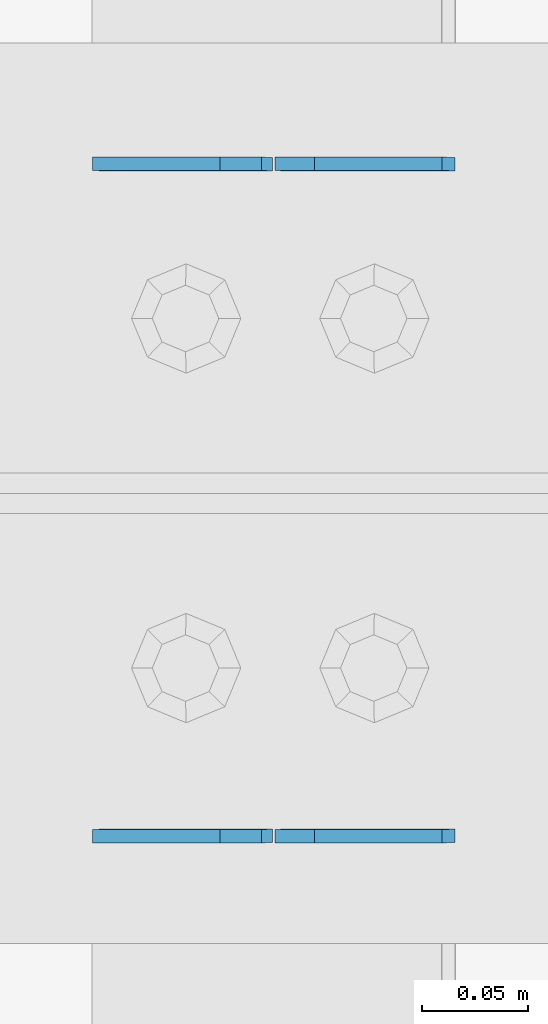
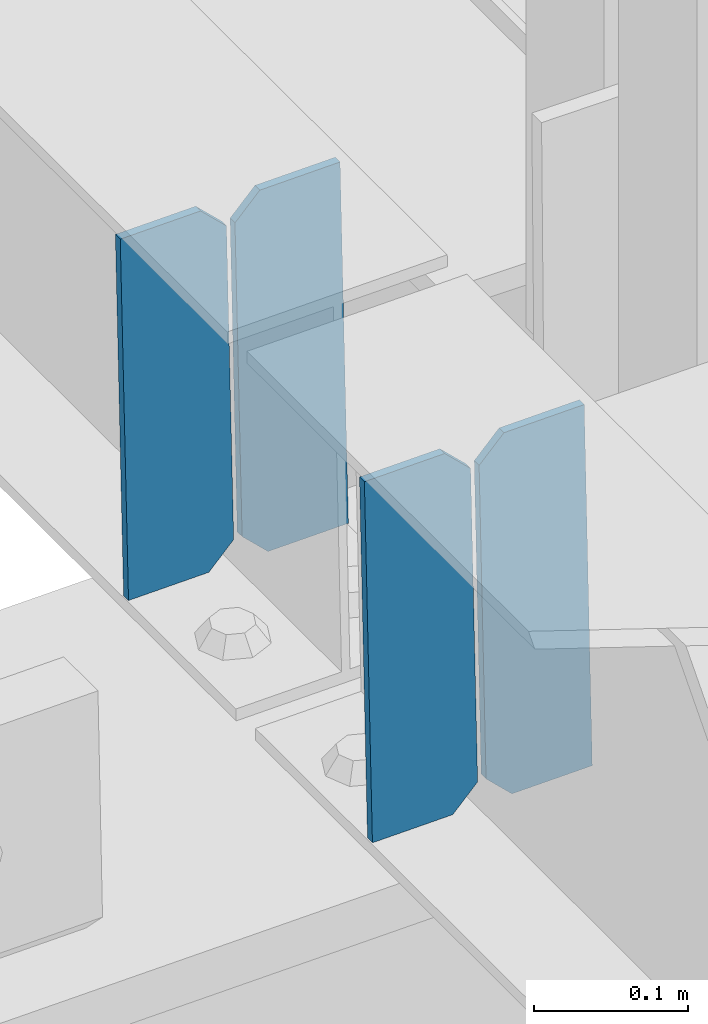
# One storey, part 3319 of 3843: 4 plates, 2 elements without a shape of their own.
"""IFC2X3 building model written with IfcOpenShell, lengths in millimetres."""

import ifcopenshell
import ifcopenshell.guid

model = None  # the IFC model being written
_history = None  # IfcOwnerHistory: only IFC2X3 demands one
_inside = {}  # id of a spatial element -> (the spatial element, [elements in it])
_under = {}  # id of a project, library or spatial element -> (it, [spatial elements below it])
_declared = {}  # id of a project -> (the project, [libraries it declares])
_typed = {}  # id of a type object -> (the type object, [elements of that type])
_made_of = {}  # id of a material, layer set ... -> (it, [elements and type objects made of it])


def new_model(schema):
    """Start an empty IFC model of exactly this schema.

    Asked for "IFC4X3", IfcOpenShell would pick the latest addendum, in which some entities
    have other attributes; the version numbers below select the first issue.
    IFC2X3 requires an IfcOwnerHistory on every rooted entity: one is made here for all.
    """
    global model, _history
    if schema == "IFC4X3":
        model = ifcopenshell.file(schema_version=(4, 3, 0, 0))
    else:
        model = ifcopenshell.file(schema=schema)
    _inside.clear()
    _under.clear()
    _declared.clear()
    _typed.clear()
    _made_of.clear()
    _history = None
    if model.schema == "IFC2X3":
        org = make("IfcOrganization", Name="unknown")
        user = make(
            "IfcPersonAndOrganization",
            ThePerson=make("IfcPerson", FamilyName="unknown"),
            TheOrganization=org,
        )
        app = make(
            "IfcApplication",
            ApplicationDeveloper=org,
            Version="unknown",
            ApplicationFullName="unknown",
            ApplicationIdentifier="unknown",
        )
        _history = make(
            "IfcOwnerHistory",
            OwningUser=user,
            OwningApplication=app,
            ChangeAction="ADDED",
            CreationDate=0,
        )
    return model


def make(cls, **values):
    """One entity of the class cls with the attributes given. An attribute that is None is left unset."""
    return model.create_entity(
        cls, **{name: value for name, value in values.items() if value is not None}
    )


def rooted(cls, **values):
    """An entity with a GlobalId (a new one), such as an element, a storey or a relation."""
    return make(cls, GlobalId=ifcopenshell.guid.new(), OwnerHistory=_history, **values)


def si_unit(unit_type, name, prefix=None):
    """IfcSIUnit, for example si_unit("LENGTHUNIT", "METRE", prefix="MILLI")."""
    return make("IfcSIUnit", UnitType=unit_type, Prefix=prefix, Name=name)


def assignment(units):
    """IfcUnitAssignment: the units of a project."""
    return None if units is None else make("IfcUnitAssignment", Units=units)


def point(xyz):
    """IfcCartesianPoint."""
    return None if xyz is None else make("IfcCartesianPoint", Coordinates=xyz)


def direction(xyz):
    """IfcDirection."""
    return None if xyz is None else make("IfcDirection", DirectionRatios=xyz)


def frame(location, z_axis=None, x_axis=None):
    """IfcAxis2Placement3D, a coordinate frame: its origin and axes. An axis left out is left unset."""
    return make(
        "IfcAxis2Placement3D",
        Location=point(location),
        Axis=direction(z_axis),
        RefDirection=direction(x_axis),
    )


def origin_with_axes():
    """The frame at (0, 0, 0) with the z axis (0, 0, 1) and the x axis (1, 0, 0) written out."""
    return frame((0.0, 0.0, 0.0), z_axis=(0.0, 0.0, 1.0), x_axis=(1.0, 0.0, 0.0))


def place(relative_to, where):
    """IfcLocalPlacement: puts the frame where relative to a parent placement (None: the world)."""
    return make(
        "IfcLocalPlacement", PlacementRelTo=relative_to, RelativePlacement=where
    )


def context(
    kind, dimensions, precision=None, world=None, true_north=None, identifier=None
):
    """IfcGeometricRepresentationContext, for example the 3D "Model" context."""
    return make(
        "IfcGeometricRepresentationContext",
        ContextIdentifier=identifier,
        ContextType=kind,
        CoordinateSpaceDimension=dimensions,
        Precision=precision,
        WorldCoordinateSystem=world,
        TrueNorth=true_north,
    )


def subcontext(parent, identifier, kind, view, scale=None):
    """IfcGeometricRepresentationSubContext, for example "Body" below "Model"."""
    return make(
        "IfcGeometricRepresentationSubContext",
        ContextIdentifier=identifier,
        ContextType=kind,
        ParentContext=parent,
        TargetScale=scale,
        TargetView=view,
    )


def project(units=None, contexts=None):
    """IfcProject with its units and contexts."""
    return rooted(
        "IfcProject",
        Name="project",
        RepresentationContexts=contexts,
        UnitsInContext=assignment(units),
    )


def spatial(cls, under=None, at=None, **own):
    """A site, building, storey or space (cls), placed at a placement, below another one or the project."""
    s = rooted(cls, ObjectPlacement=at, **own)
    if under is not None:
        _under.setdefault(under.id(), (under, []))[1].append(s)
    return s


def faces_of(points, faces, orient=None, outer=None):
    """IfcFace entities. A face is a list of loops; a loop is a list of indices into points, from 0.

    orient and outer hold one flag for each loop. By default every Orientation is true, the
    first loop of a face is its IfcFaceOuterBound and the others are IfcFaceBound.
    """
    made = []
    for i, loops in enumerate(faces):
        bounds = []
        for j, loop in enumerate(loops):
            is_outer = j == 0 if outer is None else outer[i][j]
            bounds.append(
                make(
                    "IfcFaceOuterBound" if is_outer else "IfcFaceBound",
                    Bound=make("IfcPolyLoop", Polygon=[points[k] for k in loop]),
                    Orientation=True if orient is None else orient[i][j],
                )
            )
        made.append(make("IfcFace", Bounds=bounds))
    return made


def faceted_brep(points, faces, orient=None, outer=None, voids=None):
    """IfcFacetedBrep: a solid bounded by flat faces; with voids (closed shells), ...WithVoids."""
    shared = [point(p) for p in points]
    hull = make("IfcClosedShell", CfsFaces=faces_of(shared, faces, orient, outer))
    if voids is None:
        return make("IfcFacetedBrep", Outer=hull)
    return make(
        "IfcFacetedBrepWithVoids",
        Outer=hull,
        Voids=[
            make(cls, CfsFaces=faces_of(shared, fs, o, b)) for cls, fs, o, b in voids
        ],
    )


def shape(context_of_items, identifier, shape_type, items):
    """IfcShapeRepresentation: the items that make up one representation, for example the "Body"."""
    return make(
        "IfcShapeRepresentation",
        ContextOfItems=context_of_items,
        RepresentationIdentifier=identifier,
        RepresentationType=shape_type,
        Items=items,
    )


def material(Name=None, Category=None):
    """IfcMaterial."""
    return make("IfcMaterial", Name=Name, Category=Category)


def made_of(thing, what):
    """Note that an element or type object is made of a material, layer set ...; save() writes the relation."""
    if what is not None:
        _made_of.setdefault(what.id(), (what, []))[1].append(thing)
    return thing


def type_object(cls, material=None, **own):
    """A type object (cls), such as IfcWallType, which elements share."""
    return made_of(rooted(cls, **own), material)


def element(
    cls,
    number,
    at=None,
    inside=None,
    cuts=None,
    type_object=None,
    material=None,
    context=None,
    identifier="Body",
    shape_type=None,
    held_by="IfcProductDefinitionShape",
    body=None,
    shapes=None,
    **own,
):
    """One element of the class cls, such as IfcWall. Its Tag is "e" and its number.

    at: its placement. inside: the storey or other place that contains it. cuts: it is an
    opening in that element (IfcRelVoidsElement). A single representation is given by context,
    identifier, shape_type and body (its items); several are given by shapes. held_by: the class
    of the entity that holds the representations. save() writes the other relations.
    """
    e = rooted(cls, Tag="e%d" % number, ObjectPlacement=at, **own)
    if body is not None:
        shapes = [shape(context, identifier, shape_type, body)]
    if shapes is not None:
        e.Representation = make(held_by, Representations=shapes)
    if inside is not None:
        _inside.setdefault(inside.id(), (inside, []))[1].append(e)
    if cuts is not None:
        rooted(
            "IfcRelVoidsElement", RelatingBuildingElement=cuts, RelatedOpeningElement=e
        )
    if type_object is not None:
        _typed.setdefault(type_object.id(), (type_object, []))[1].append(e)
    return made_of(e, material)


def aggregate(whole, parts):
    """IfcRelAggregates: a whole, such as a stair, and the parts it consists of."""
    return rooted("IfcRelAggregates", RelatingObject=whole, RelatedObjects=parts)


def save(model, path):
    """Write the relations noted so far, then the file.

    IfcRelAggregates (storeys below a building ...), IfcRelContainedInSpatialStructure (elements
    in a storey), IfcRelDefinesByType, IfcRelAssociatesMaterial and IfcRelDeclares: one each for
    every whole, place, type object, material and project.
    """
    for whole, parts in _under.values():
        aggregate(whole, parts)
    for where, things in _inside.values():
        rooted(
            "IfcRelContainedInSpatialStructure",
            RelatedElements=things,
            RelatingStructure=where,
        )
    for kind, things in _typed.values():
        rooted("IfcRelDefinesByType", RelatedObjects=things, RelatingType=kind)
    for what, things in _made_of.values():
        rooted("IfcRelAssociatesMaterial", RelatedObjects=things, RelatingMaterial=what)
    for by, libraries in _declared.values():
        rooted("IfcRelDeclares", RelatingContext=by, RelatedDefinitions=libraries)
    model.write(path)


model = new_model("IFC2X3")

# Units and contexts
model_context = context("Model", 3, precision=1e-05, world=origin_with_axes())
body_context = subcontext(model_context, "Body", "Model", "MODEL_VIEW")
ifc_project = project(units=[si_unit("LENGTHUNIT", "METRE", prefix="MILLI"), si_unit("AREAUNIT", "SQUARE_METRE"), si_unit("VOLUMEUNIT", "CUBIC_METRE"), si_unit("MASSUNIT", "GRAM", prefix="KILO"), si_unit("TIMEUNIT", "SECOND"), si_unit("PLANEANGLEUNIT", "RADIAN"), si_unit("SOLIDANGLEUNIT", "STERADIAN"), si_unit("THERMODYNAMICTEMPERATUREUNIT", "DEGREE_CELSIUS"), si_unit("LUMINOUSINTENSITYUNIT", "LUMEN")], contexts=[model_context])

# Site, building, storey
site_placement = place(None, origin_with_axes())
site = spatial("IfcSite", under=ifc_project, at=site_placement, CompositionType="ELEMENT")
building_placement = place(site_placement, origin_with_axes())
building = spatial("IfcBuilding", under=site, at=building_placement, Name="Undefined", CompositionType="ELEMENT")
storey_placement = place(building_placement, origin_with_axes())
storey = spatial("IfcBuildingStorey", under=building, at=storey_placement, Name="Undefined", CompositionType="ELEMENT", Elevation=0.0)

# Assembly, plates
assembly_1_placement = place(storey_placement, origin_with_axes())
assembly_1 = element("IfcElementAssembly", 1, at=assembly_1_placement, inside=storey, Name="BEAM", AssemblyPlace="NOTDEFINED", PredefinedType="RIGID_FRAME")
ifc_material = material(Name="STEEL/A572-50")
plate_type = type_object("IfcPlateType", PredefinedType="NOTDEFINED")
plate_1_placement = place(assembly_1_placement, frame((72027.7964817318, 59070.7249093812, 46280.52202897), z_axis=(-0.0211520976735046, 0.000503028999904926, 0.999776142806896), x_axis=(-0.999776269357269, -1.03370000525781e-05, -0.0211520950075214)))
plate_1 = element("IfcPlate", 2, at=plate_1_placement, type_object=plate_type, material=ifc_material, Name="PLATE", context=body_context, shape_type="Brep", body=[
    faceted_brep([(0.0, -3.17499999999927, 0.0), (6.83940015733242e-10, -3.17499999996653, 288.924999998613), (6.54836185276508e-10, 3.17500000001746, 288.924999998591), (0.0, 3.17499999999927, 0.0), (60.3250007643655, -3.17500000017753, 288.924999998606), (60.3250007643219, 3.17499999979918, 288.924999998584), (79.3750000013097, -3.17500000025029, 269.875000761494), (79.375000001266, 3.17499999972642, 269.875000761487), (79.375000000713, -3.17500000026484, 19.0499992370605), (79.3750000006985, 3.17499999971187, 19.0499992370533), (60.325000763667, -3.17500000020664, -1.45519152283669e-11), (60.3250007636234, 3.17499999977736, -3.63797880709171e-11)], [[[0, 1, 2, 3]], [[1, 4, 5, 2]], [[4, 6, 7, 5]], [[6, 8, 9, 7]], [[8, 10, 11, 9]], [[10, 0, 3, 11]], [[5, 7, 9, 11, 3, 2]], [[10, 8, 6, 4, 1, 0]]]),
])
plate_2_placement = place(assembly_1_placement, frame((71942.0906610415, 59070.7239989397, 46278.7087655975), z_axis=(-0.0211520976735046, 0.000503028999904926, 0.999776142806896), x_axis=(-0.999776269357269, -1.03370000525781e-05, -0.0211520950075214)))
plate_2 = element("IfcPlate", 3, at=plate_2_placement, type_object=plate_type, material=ifc_material, Name="PLATE", context=body_context, shape_type="Brep", body=[
    faceted_brep([(4.36557456851006e-11, -3.17499999998836, 19.0499992370969), (6.11180439591408e-10, -3.17499999996653, 269.875000761516), (5.96628524363041e-10, 3.17500000001746, 269.875000761502), (1.45519152283669e-11, 3.17499999998836, 19.0499992370824), (19.0499992376572, -3.17500000003201, 288.924999998606), (19.0499992376281, 3.1749999999447, 288.924999998584), (79.3750000013242, -3.17500000025029, 288.924999998591), (79.3750000013097, 3.1749999997337, 288.92499999857), (79.3750000006548, -3.17500000026484, -2.18278728425503e-11), (79.3750000006403, 3.17499999969732, -2.91038304567337e-11), (19.0499992370023, -3.17500000005384, 0.0), (19.0499992369587, 3.17499999992287, -1.45519152283669e-11)], [[[0, 1, 2, 3]], [[1, 4, 5, 2]], [[4, 6, 7, 5]], [[6, 8, 9, 7]], [[8, 10, 11, 9]], [[10, 0, 3, 11]], [[5, 7, 9, 11, 3, 2]], [[10, 8, 6, 4, 1, 0]]]),
])
aggregate(assembly_1, [plate_1, plate_2])

assembly_2_placement = place(storey_placement, origin_with_axes())
assembly_2 = element("IfcElementAssembly", 4, at=assembly_2_placement, inside=storey, Name="BEAM", AssemblyPlace="NOTDEFINED", PredefinedType="RIGID_FRAME")
plate_3_placement = place(assembly_2_placement, frame((72027.7964782844, 58753.5253247873, 46280.5187064123), z_axis=(-0.0211520976931496, -0.000503817000200796, 0.999776142409695), x_axis=(-0.999776269357268, 1.0337000006824e-05, -0.0211520950075907)))
plate_3 = element("IfcPlate", 5, at=plate_3_placement, type_object=plate_type, material=ifc_material, Name="PLATE", context=body_context, shape_type="Brep", body=[
    faceted_brep([(0.0, -3.17499999999927, 0.0), (6.83940015733242e-10, -3.17499999996653, 288.924999998613), (6.54836185276508e-10, 3.17500000001746, 288.924999998591), (0.0, 3.17499999999927, 0.0), (60.3250007643655, -3.17500000017753, 288.924999998606), (60.3250007643219, 3.17499999979918, 288.924999998584), (79.3750000013097, -3.17500000025029, 269.875000761494), (79.375000001266, 3.17499999972642, 269.875000761487), (79.375000000713, -3.17500000026484, 19.0499992370605), (79.3750000006985, 3.17499999971187, 19.0499992370533), (60.325000763667, -3.17500000020664, -1.45519152283669e-11), (60.3250007636234, 3.17499999977736, -3.63797880709171e-11)], [[[0, 1, 2, 3]], [[1, 4, 5, 2]], [[4, 6, 7, 5]], [[6, 8, 9, 7]], [[8, 10, 11, 9]], [[10, 0, 3, 11]], [[5, 7, 9, 11, 3, 2]], [[10, 8, 6, 4, 1, 0]]]),
])
plate_4_placement = place(assembly_2_placement, frame((71942.0906575932, 58753.5262385444, 46278.7054430406), z_axis=(-0.0211520976931496, -0.000503817000200796, 0.999776142409695), x_axis=(-0.999776269357268, 1.0337000006824e-05, -0.0211520950075907)))
plate_4 = element("IfcPlate", 6, at=plate_4_placement, type_object=plate_type, material=ifc_material, Name="PLATE", context=body_context, shape_type="Brep", body=[
    faceted_brep([(4.36557456851006e-11, -3.17499999998836, 19.0499992370969), (6.11180439591408e-10, -3.17499999996653, 269.875000761516), (5.96628524363041e-10, 3.17500000001746, 269.875000761502), (1.45519152283669e-11, 3.17499999998836, 19.0499992370824), (19.0499992376572, -3.17500000003201, 288.924999998606), (19.0499992376281, 3.1749999999447, 288.924999998584), (79.3750000013242, -3.17500000025029, 288.924999998591), (79.3750000013097, 3.1749999997337, 288.92499999857), (79.3750000006548, -3.17500000026484, -2.18278728425503e-11), (79.3750000006403, 3.17499999969732, -2.91038304567337e-11), (19.0499992370023, -3.17500000005384, 0.0), (19.0499992369587, 3.17499999992287, -1.45519152283669e-11)], [[[0, 1, 2, 3]], [[1, 4, 5, 2]], [[4, 6, 7, 5]], [[6, 8, 9, 7]], [[8, 10, 11, 9]], [[10, 0, 3, 11]], [[5, 7, 9, 11, 3, 2]], [[10, 8, 6, 4, 1, 0]]]),
])
aggregate(assembly_2, [plate_3, plate_4])

save(model, "model.ifc")
